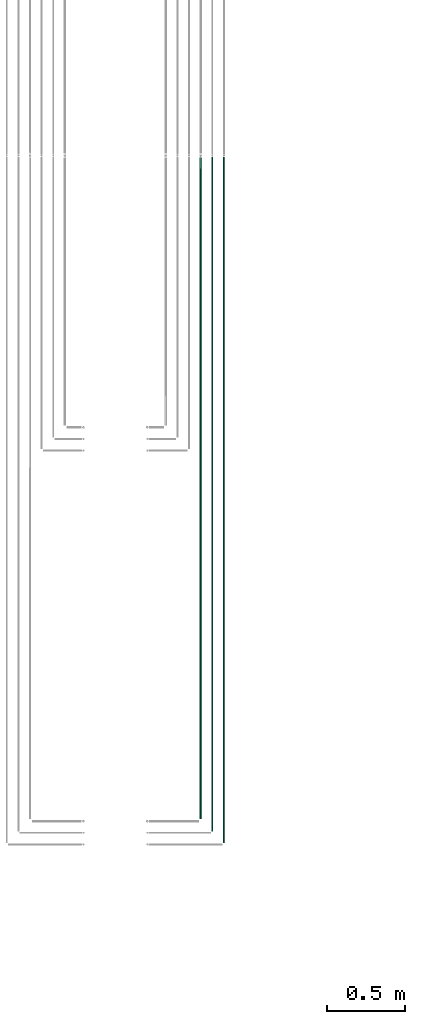
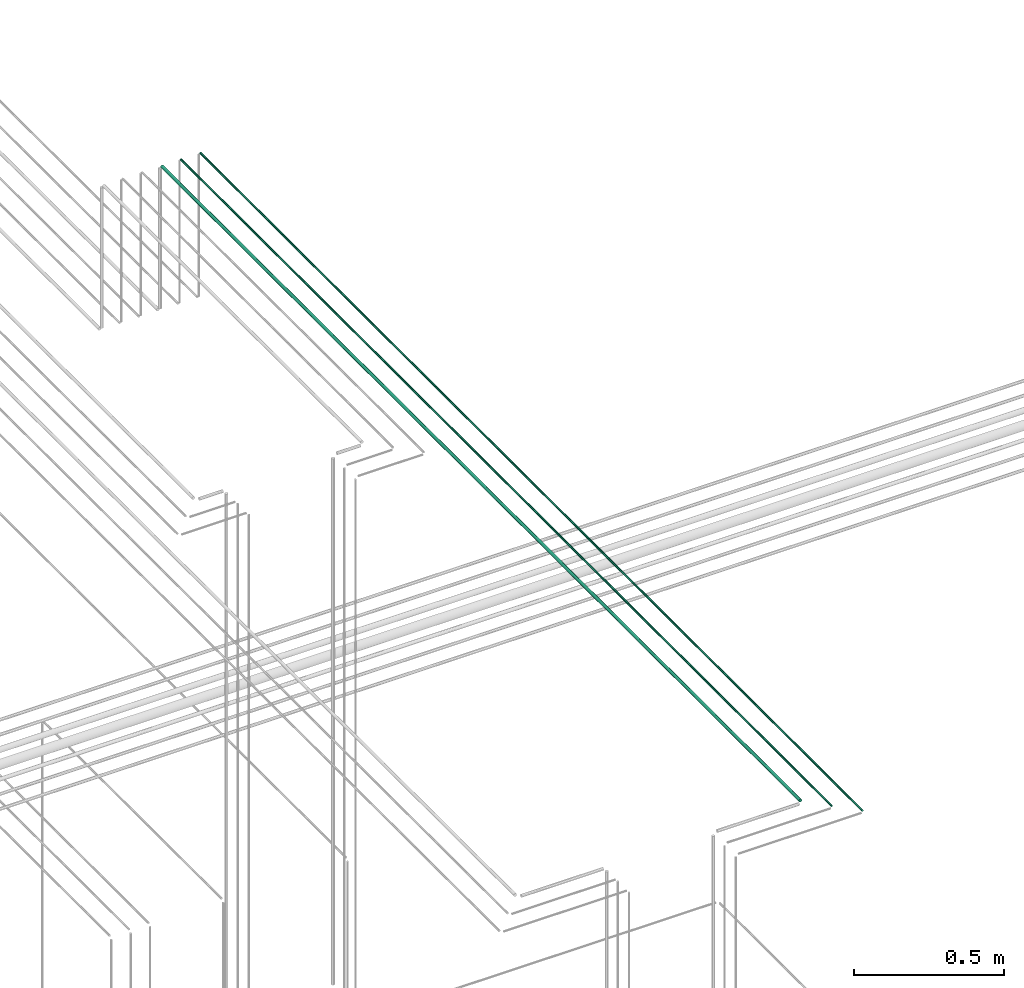
# One storey, part 61 of 331: 3 flow segments.
"""IFC2X3 building model written with IfcOpenShell, lengths in millimetres."""

from ifc_helpers import new_model, entity, si_unit, converted_unit, derived_unit, direction, frame, origin, origin_2d_with_axis, place, context, subcontext, project, spatial, circle, extrude, type_object, element, save


model = new_model("IFC2X3")

# Units and contexts
model_context = context("Model", 3, precision=0.01, world=origin(), true_north=direction((6.12303176911189e-17, 1.0)))
body_context = subcontext(model_context, "Body", "Model", "MODEL_VIEW")
ifc_project = project(units=[si_unit("LENGTHUNIT", "METRE", prefix="MILLI"), si_unit("AREAUNIT", "SQUARE_METRE"), si_unit("VOLUMEUNIT", "CUBIC_METRE"), converted_unit("PLANEANGLEUNIT", "DEGREE", entity("IfcRatioMeasure", 0.0174532925199433), si_unit("PLANEANGLEUNIT", "RADIAN"), dimensions=[0, 0, 0, 0, 0, 0, 0]), si_unit("MASSUNIT", "GRAM", prefix="KILO"), derived_unit("MASSDENSITYUNIT", [(si_unit("MASSUNIT", "GRAM", prefix="KILO"), 1), (si_unit("LENGTHUNIT", "METRE"), -3)]), derived_unit("MOMENTOFINERTIAUNIT", [(si_unit("LENGTHUNIT", "METRE"), 4)]), si_unit("TIMEUNIT", "SECOND"), si_unit("FREQUENCYUNIT", "HERTZ"), si_unit("THERMODYNAMICTEMPERATUREUNIT", "DEGREE_CELSIUS"), derived_unit("THERMALTRANSMITTANCEUNIT", [(si_unit("MASSUNIT", "GRAM", prefix="KILO"), 1), (si_unit("THERMODYNAMICTEMPERATUREUNIT", "KELVIN"), -1), (si_unit("TIMEUNIT", "SECOND"), -3)]), derived_unit("VOLUMETRICFLOWRATEUNIT", [(si_unit("LENGTHUNIT", "METRE"), 3), (si_unit("TIMEUNIT", "SECOND"), -1)]), derived_unit("MASSFLOWRATEUNIT", [(si_unit("MASSUNIT", "GRAM", prefix="KILO"), 1), (si_unit("TIMEUNIT", "SECOND"), -1)]), derived_unit("ROTATIONALFREQUENCYUNIT", [(si_unit("TIMEUNIT", "SECOND"), -1)]), si_unit("ELECTRICCURRENTUNIT", "AMPERE"), si_unit("ELECTRICVOLTAGEUNIT", "VOLT"), si_unit("POWERUNIT", "WATT"), si_unit("FORCEUNIT", "NEWTON", prefix="KILO"), si_unit("ILLUMINANCEUNIT", "LUX"), si_unit("LUMINOUSFLUXUNIT", "LUMEN"), si_unit("LUMINOUSINTENSITYUNIT", "CANDELA"), derived_unit("USERDEFINED", [(si_unit("MASSUNIT", "GRAM", prefix="KILO"), -1), (si_unit("LENGTHUNIT", "METRE"), -2), (si_unit("TIMEUNIT", "SECOND"), 3), (si_unit("LUMINOUSFLUXUNIT", "LUMEN"), 1)]), derived_unit("LINEARVELOCITYUNIT", [(si_unit("LENGTHUNIT", "METRE"), 1), (si_unit("TIMEUNIT", "SECOND"), -1)]), si_unit("PRESSUREUNIT", "PASCAL"), derived_unit("USERDEFINED", [(si_unit("LENGTHUNIT", "METRE"), -2), (si_unit("MASSUNIT", "GRAM", prefix="KILO"), 1), (si_unit("TIMEUNIT", "SECOND"), -2)]), derived_unit("LINEARFORCEUNIT", [(si_unit("MASSUNIT", "GRAM", prefix="KILO"), 1), (si_unit("LENGTHUNIT", "METRE"), 1), (si_unit("TIMEUNIT", "SECOND"), -2), (si_unit("LENGTHUNIT", "METRE"), -1)]), derived_unit("PLANARFORCEUNIT", [(si_unit("MASSUNIT", "GRAM", prefix="KILO"), 1), (si_unit("LENGTHUNIT", "METRE"), 1), (si_unit("TIMEUNIT", "SECOND"), -2), (si_unit("LENGTHUNIT", "METRE"), -2)])], contexts=[model_context])

# Site, building, storey
site_placement = place(None, frame((0.0, -0.00077364408347762, 0.0)))
site = spatial("IfcSite", under=ifc_project, at=site_placement, CompositionType="ELEMENT")
building_placement = place(site_placement, origin())
building = spatial("IfcBuilding", under=site, at=building_placement, CompositionType="ELEMENT")
storey_placement = place(building_placement, origin())
storey = spatial("IfcBuildingStorey", under=building, at=storey_placement, CompositionType="ELEMENT", Elevation=0.0)

# Flow segments
pipe_segment_type = type_object("IfcPipeSegmentType", PredefinedType="NOTDEFINED")
flow_segment_1_placement = place(storey_placement, frame((53912.5706481368, 1365.48876707966, 19042.4047277641)))
element("IfcFlowSegment", 1, at=flow_segment_1_placement, inside=storey, type_object=pipe_segment_type, context=body_context, shape_type="SweptSolid", body=[
    extrude(circle(Radius=6.0, at=origin_2d_with_axis()), frame((7.59527223591454, 0.0, 7.5952722359167), z_axis=(0.0, 1.0, 0.0), x_axis=(1.0, 0.0, 0.0)), (0.0, 0.0, 1.0), 4264.13179674766),
])
flow_segment_2_placement = place(storey_placement, frame((53989.5706481368, 1286.48876707966, 19044.4047277641)))
element("IfcFlowSegment", 2, at=flow_segment_2_placement, inside=storey, type_object=pipe_segment_type, context=body_context, shape_type="SweptSolid", body=[
    extrude(circle(Radius=4.0, at=origin_2d_with_axis()), frame((5.59527223591499, 0.0, 5.59527223591499), z_axis=(0.0, 1.0, 0.0), x_axis=(1.0, 0.0, 0.0)), (0.0, 0.0, 1.0), 4347.13179674766),
])
flow_segment_3_placement = place(storey_placement, frame((54064.5706481368, 1211.48876707966, 19044.4047277641)))
element("IfcFlowSegment", 3, at=flow_segment_3_placement, inside=storey, type_object=pipe_segment_type, context=body_context, shape_type="SweptSolid", body=[
    extrude(circle(Radius=4.0, at=origin_2d_with_axis()), frame((5.59527223591499, 0.0, 5.59527223591499), z_axis=(0.0, 1.0, 0.0), x_axis=(1.0, 0.0, 0.0)), (0.0, 0.0, 1.0), 4422.13179674766),
])

save(model, "model.ifc")
